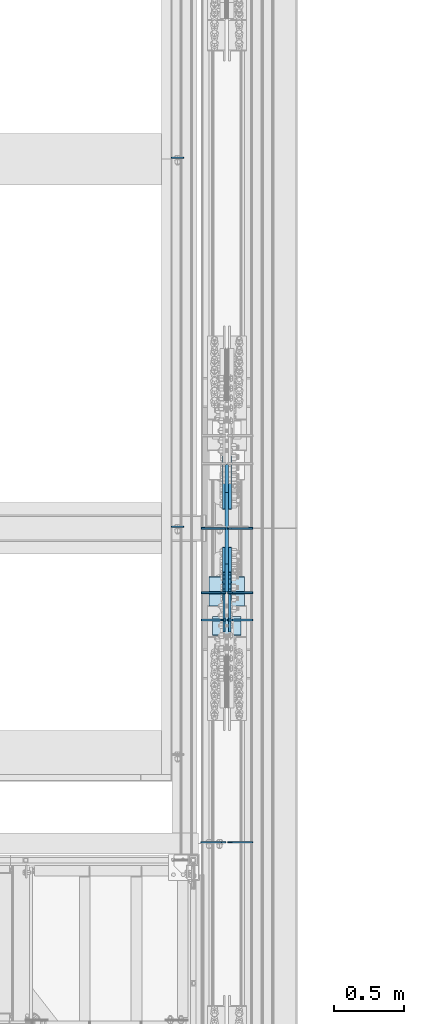
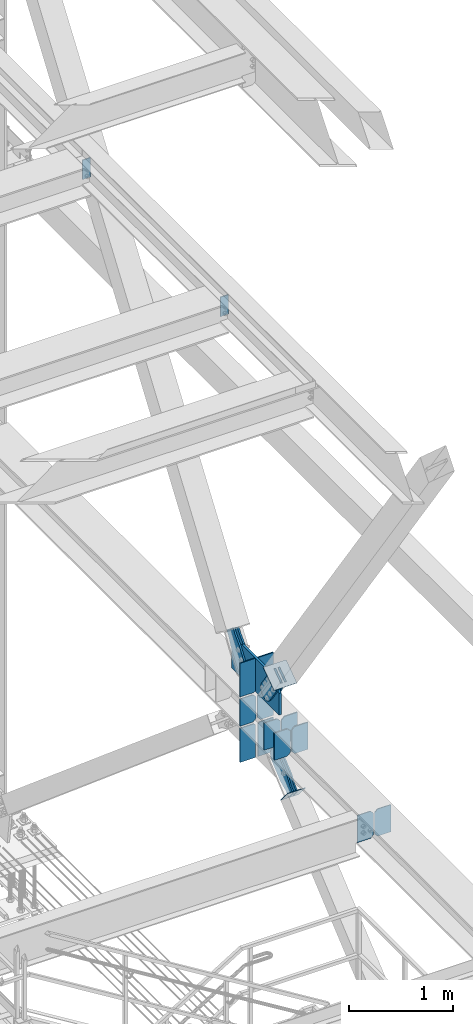
# One storey, part 3572 of 3843: 23 plates, 10 elements without a shape of their own.
"""IFC2X3 building model written with IfcOpenShell, lengths in millimetres."""

from ifc_helpers import new_model, si_unit, frame, origin_with_axes, place, context, subcontext, project, spatial, faceted_brep, material, type_object, element, aggregate, save


model = new_model("IFC2X3")

# Units and contexts
model_context = context("Model", 3, precision=1e-05, world=origin_with_axes())
body_context = subcontext(model_context, "Body", "Model", "MODEL_VIEW")
ifc_project = project(units=[si_unit("LENGTHUNIT", "METRE", prefix="MILLI"), si_unit("AREAUNIT", "SQUARE_METRE"), si_unit("VOLUMEUNIT", "CUBIC_METRE"), si_unit("MASSUNIT", "GRAM", prefix="KILO"), si_unit("TIMEUNIT", "SECOND"), si_unit("PLANEANGLEUNIT", "RADIAN"), si_unit("SOLIDANGLEUNIT", "STERADIAN"), si_unit("THERMODYNAMICTEMPERATUREUNIT", "DEGREE_CELSIUS"), si_unit("LUMINOUSINTENSITYUNIT", "LUMEN")], contexts=[model_context])

# Site, building, storey
site_placement = place(None, origin_with_axes())
site = spatial("IfcSite", under=ifc_project, at=site_placement, CompositionType="ELEMENT")
building_placement = place(site_placement, origin_with_axes())
building = spatial("IfcBuilding", under=site, at=building_placement, Name="Undefined", CompositionType="ELEMENT")
storey_placement = place(building_placement, origin_with_axes())
storey = spatial("IfcBuildingStorey", under=building, at=storey_placement, Name="Undefined", CompositionType="ELEMENT", Elevation=0.0)

# Assembly, plates
assembly_1_placement = place(storey_placement, origin_with_axes())
assembly_1 = element("IfcElementAssembly", 1, at=assembly_1_placement, inside=storey, Name="BEAM", AssemblyPlace="NOTDEFINED", PredefinedType="RIGID_FRAME")
ifc_material_1 = material(Name="STEEL/A572-50")
plate_type_1 = type_object("IfcPlateType", PredefinedType="NOTDEFINED")
plate_1_placement = place(assembly_1_placement, frame((85338.44375, 20317.61875, 39573.2), z_axis=(-1.0, 0.0, 0.0), x_axis=(0.0, 0.0, -1.0)))
plate_1 = element("IfcPlate", 2, at=plate_1_placement, type_object=plate_type_1, material=ifc_material_1, Name="PLATE", context=body_context, shape_type="Brep", body=[
    faceted_brep([(0.0, -4.76249999999709, 0.0), (0.0, -4.76249999999709, 88.9000015258789), (0.0, 4.76249999999709, 88.9000015258789), (0.0, 4.76249999999709, 0.0), (228.600006102781, -4.7625000004191, 88.9000015257589), (228.600006102781, 4.76249999954598, 88.9000015257443), (228.600006103079, -4.7625000004482, 7.27595761418343e-12), (228.600006103079, 4.76249999954598, -7.27595761418343e-12)], [[[0, 1, 2, 3]], [[1, 4, 5, 2]], [[4, 6, 7, 5]], [[6, 0, 3, 7]], [[5, 7, 3, 2]], [[6, 4, 1, 0]]]),
])
plate_2_placement = place(assembly_1_placement, frame((85338.44375, 22971.91875, 39573.2), z_axis=(-1.0, 0.0, 0.0), x_axis=(0.0, 0.0, -1.0)))
plate_2 = element("IfcPlate", 3, at=plate_2_placement, type_object=plate_type_1, material=ifc_material_1, Name="PLATE", context=body_context, shape_type="Brep", body=[
    faceted_brep([(0.0, -4.76249999999709, 0.0), (0.0, -4.76249999999709, 88.9000015258789), (0.0, 4.76249999999709, 88.9000015258789), (0.0, 4.76249999999709, 0.0), (228.600006102781, -4.7625000004191, 88.9000015257589), (228.600006102781, 4.76249999954598, 88.9000015257443), (228.600006103079, -4.7625000004482, 7.27595761418343e-12), (228.600006103079, 4.76249999954598, -7.27595761418343e-12)], [[[0, 1, 2, 3]], [[1, 4, 5, 2]], [[4, 6, 7, 5]], [[6, 0, 3, 7]], [[5, 7, 3, 2]], [[6, 4, 1, 0]]]),
])
aggregate(assembly_1, [plate_1, plate_2])

assembly_2_placement = place(storey_placement, origin_with_axes())
assembly_2 = element("IfcElementAssembly", 4, at=assembly_2_placement, inside=storey, Name="BEAM", AssemblyPlace="NOTDEFINED", PredefinedType="RIGID_FRAME")
plate_type_2 = type_object("IfcPlateType", PredefinedType="NOTDEFINED")
plate_3_placement = place(assembly_2_placement, frame((85641.65625, 19647.4953120779, 34467.8), z_axis=(-1.0, 0.0, 0.0), x_axis=(0.0, 0.0, 1.0)))
plate_3 = element("IfcPlate", 5, at=plate_3_placement, type_object=plate_type_2, material=ifc_material_1, Name="CB_BEAM", context=body_context, shape_type="Brep", body=[
    faceted_brep([(0.0, -6.34999999999854, 33.3375015258789), (0.0, -6.34999999999854, 178.59375), (0.0, 6.34999999999854, 178.59375), (0.0, 6.34999999999854, 33.3375015258789), (317.499999999985, -6.34999999999854, 178.59375), (317.499999999985, 6.34999999999854, 178.59375), (317.499999999985, -6.34999999999854, 33.3375015258789), (317.499999999985, 6.34999999999854, 33.3375015258789), (284.162498474107, -6.34999999999854, 0.0), (284.162498474107, 6.34999999999854, 0.0), (33.3375015258789, -6.34999999999854, 0.0), (33.3375015258789, 6.34999999999854, 0.0)], [[[0, 1, 2, 3]], [[1, 4, 5, 2]], [[4, 6, 7, 5]], [[6, 8, 9, 7]], [[8, 10, 11, 9]], [[10, 0, 3, 11]], [[5, 7, 9, 11, 3, 2]], [[10, 8, 6, 4, 1, 0]]]),
])
plate_4_placement = place(assembly_2_placement, frame((85641.65625, 19843.5515620779, 34467.8), z_axis=(-1.0, 0.0, 0.0), x_axis=(0.0, 0.0, 1.0)))
plate_4 = element("IfcPlate", 6, at=plate_4_placement, type_object=plate_type_2, material=ifc_material_1, Name="CB_BEAM", context=body_context, shape_type="Brep", body=[
    faceted_brep([(0.0, -6.34999999999854, 33.3375015258789), (0.0, -6.34999999999854, 178.59375), (0.0, 6.34999999999854, 178.59375), (0.0, 6.34999999999854, 33.3375015258789), (317.499999999985, -6.34999999999854, 178.59375), (317.499999999985, 6.34999999999854, 178.59375), (317.499999999985, -6.34999999999854, 33.3375015258789), (317.499999999985, 6.34999999999854, 33.3375015258789), (284.162498474107, -6.34999999999854, 0.0), (284.162498474107, 6.34999999999854, 0.0), (33.3375015258789, -6.34999999999854, 0.0), (33.3375015258789, 6.34999999999854, 0.0)], [[[0, 1, 2, 3]], [[1, 4, 5, 2]], [[4, 6, 7, 5]], [[6, 8, 9, 7]], [[8, 10, 11, 9]], [[10, 0, 3, 11]], [[5, 7, 9, 11, 3, 2]], [[10, 8, 6, 4, 1, 0]]]),
])
plate_5_placement = place(assembly_2_placement, frame((85655.94375, 19647.4953120779, 34467.8), z_axis=(1.0, 0.0, 0.0), x_axis=(0.0, 0.0, 1.0)))
plate_5 = element("IfcPlate", 7, at=plate_5_placement, type_object=plate_type_2, material=ifc_material_1, Name="CB_BEAM", context=body_context, shape_type="Brep", body=[
    faceted_brep([(0.0, -6.34999999999854, 33.3375015258789), (0.0, -6.34999999999854, 178.59375), (0.0, 6.34999999999854, 178.59375), (0.0, 6.34999999999854, 33.3375015258789), (317.499999999985, -6.34999999999854, 178.59375), (317.499999999985, 6.34999999999854, 178.59375), (317.499999999985, -6.34999999999854, 33.3375015258789), (317.499999999985, 6.34999999999854, 33.3375015258789), (284.162498474107, -6.34999999999854, 0.0), (284.162498474107, 6.34999999999854, 0.0), (33.3375015258789, -6.34999999999854, 0.0), (33.3375015258789, 6.34999999999854, 0.0)], [[[0, 1, 2, 3]], [[1, 4, 5, 2]], [[4, 6, 7, 5]], [[6, 8, 9, 7]], [[8, 10, 11, 9]], [[10, 0, 3, 11]], [[5, 7, 9, 11, 3, 2]], [[10, 8, 6, 4, 1, 0]]]),
])
plate_6_placement = place(assembly_2_placement, frame((85655.94375, 19843.5515620779, 34467.8), z_axis=(1.0, 0.0, 0.0), x_axis=(0.0, 0.0, 1.0)))
plate_6 = element("IfcPlate", 8, at=plate_6_placement, type_object=plate_type_2, material=ifc_material_1, Name="CB_BEAM", context=body_context, shape_type="Brep", body=[
    faceted_brep([(0.0, -6.34999999999854, 33.3375015258789), (0.0, -6.34999999999854, 178.59375), (0.0, 6.34999999999854, 178.59375), (0.0, 6.34999999999854, 33.3375015258789), (317.499999999985, -6.34999999999854, 178.59375), (317.499999999985, 6.34999999999854, 178.59375), (317.499999999985, -6.34999999999854, 33.3375015258789), (317.499999999985, 6.34999999999854, 33.3375015258789), (284.162498474107, -6.34999999999854, 0.0), (284.162498474107, 6.34999999999854, 0.0), (33.3375015258789, -6.34999999999854, 0.0), (33.3375015258789, 6.34999999999854, 0.0)], [[[0, 1, 2, 3]], [[1, 4, 5, 2]], [[4, 6, 7, 5]], [[6, 8, 9, 7]], [[8, 10, 11, 9]], [[10, 0, 3, 11]], [[5, 7, 9, 11, 3, 2]], [[10, 8, 6, 4, 1, 0]]]),
])
plate_7_placement = place(assembly_2_placement, frame((85641.65625, 20307.3000000779, 34467.8), z_axis=(-1.0, 0.0, 0.0), x_axis=(0.0, 0.0, 1.0)))
plate_7 = element("IfcPlate", 9, at=plate_7_placement, type_object=plate_type_2, material=ifc_material_1, Name="CB_BEAM", context=body_context, shape_type="Brep", body=[
    faceted_brep([(0.0, -6.34999999999854, 33.3375015258789), (0.0, -6.34999999999854, 178.59375), (0.0, 6.34999999999854, 178.59375), (0.0, 6.34999999999854, 33.3375015258789), (317.499999999985, -6.34999999999854, 178.59375), (317.499999999985, 6.34999999999854, 178.59375), (317.499999999985, -6.34999999999854, 33.3375015258789), (317.499999999985, 6.34999999999854, 33.3375015258789), (284.162498474107, -6.34999999999854, 0.0), (284.162498474107, 6.34999999999854, 0.0), (33.3375015258789, -6.34999999999854, 0.0), (33.3375015258789, 6.34999999999854, 0.0)], [[[0, 1, 2, 3]], [[1, 4, 5, 2]], [[4, 6, 7, 5]], [[6, 8, 9, 7]], [[8, 10, 11, 9]], [[10, 0, 3, 11]], [[5, 7, 9, 11, 3, 2]], [[10, 8, 6, 4, 1, 0]]]),
])
plate_8_placement = place(assembly_2_placement, frame((85655.94375, 20307.3000000779, 34467.8), z_axis=(1.0, 0.0, 0.0), x_axis=(0.0, 0.0, 1.0)))
plate_8 = element("IfcPlate", 10, at=plate_8_placement, type_object=plate_type_2, material=ifc_material_1, Name="CB_BEAM", context=body_context, shape_type="Brep", body=[
    faceted_brep([(0.0, -6.34999999999854, 33.3375015258789), (0.0, -6.34999999999854, 178.59375), (0.0, 6.34999999999854, 178.59375), (0.0, 6.34999999999854, 33.3375015258789), (317.499999999985, -6.34999999999854, 178.59375), (317.499999999985, 6.34999999999854, 178.59375), (317.499999999985, -6.34999999999854, 33.3375015258789), (317.499999999985, 6.34999999999854, 33.3375015258789), (284.162498474107, -6.34999999999854, 0.0), (284.162498474107, 6.34999999999854, 0.0), (33.3375015258789, -6.34999999999854, 0.0), (33.3375015258789, 6.34999999999854, 0.0)], [[[0, 1, 2, 3]], [[1, 4, 5, 2]], [[4, 6, 7, 5]], [[6, 8, 9, 7]], [[8, 10, 11, 9]], [[10, 0, 3, 11]], [[5, 7, 9, 11, 3, 2]], [[10, 8, 6, 4, 1, 0]]]),
])
plate_type_3 = type_object("IfcPlateType", PredefinedType="NOTDEFINED")
plate_9_placement = place(assembly_2_placement, frame((85636.1, 20307.3000000779, 34042.945312), z_axis=(-1.0, 0.0, 0.0), x_axis=(0.0, 0.0, 1.0)))
plate_9 = element("IfcPlate", 11, at=plate_9_placement, type_object=plate_type_3, material=ifc_material_1, Name="CB", context=body_context, shape_type="Brep", body=[
    faceted_brep([(0.0, -6.3499999046162, 0.0), (0.0, -6.34999999999854, 173.037500000006), (0.0, 6.34999999999854, 173.037500000006), (7.27595761418343e-12, 6.3499999046162, 0.0), (399.501140829176, -6.34999999999854, 173.037500000006), (399.501140829176, 6.34999999999854, 173.037500000006), (399.501140829176, -6.34999999999854, 19.0499992370605), (399.501140829176, 6.34999999999854, 19.0499992370605), (380.451141592115, -6.34999999999854, 0.0), (380.451141592115, 6.34999999999854, 0.0)], [[[0, 1, 2, 3]], [[1, 4, 5, 2]], [[4, 6, 7, 5]], [[6, 8, 9, 7]], [[8, 0, 3, 9]], [[5, 7, 9, 3, 2]], [[8, 6, 4, 1, 0]]]),
])
plate_10_placement = place(assembly_2_placement, frame((85661.5, 20307.3000000779, 34042.945312), z_axis=(1.0, 0.0, 0.0), x_axis=(0.0, 0.0, 1.0)))
plate_10 = element("IfcPlate", 12, at=plate_10_placement, type_object=plate_type_3, material=ifc_material_1, Name="CB", context=body_context, shape_type="Brep", body=[
    faceted_brep([(0.0, -6.3499999046162, 0.0), (0.0, -6.34999999999854, 173.037500000006), (0.0, 6.34999999999854, 173.037500000006), (7.27595761418343e-12, 6.3499999046162, 0.0), (399.501140829176, -6.34999999999854, 173.037500000006), (399.501140829176, 6.34999999999854, 173.037500000006), (399.501140829176, -6.34999999999854, 19.0499992370605), (399.501140829176, 6.34999999999854, 19.0499992370605), (380.451141592115, -6.34999999999854, 0.0), (380.451141592115, 6.34999999999854, 0.0)], [[[0, 1, 2, 3]], [[1, 4, 5, 2]], [[4, 6, 7, 5]], [[6, 8, 9, 7]], [[8, 0, 3, 9]], [[5, 7, 9, 3, 2]], [[8, 6, 4, 1, 0]]]),
])
plate_11_placement = place(assembly_2_placement, frame((85636.1, 20307.3000000779, 34810.7), z_axis=(-1.0, 0.0, 0.0), x_axis=(0.0, 0.0, 1.0)))
plate_11 = element("IfcPlate", 13, at=plate_11_placement, type_object=plate_type_3, material=ifc_material_1, Name="CB", context=body_context, shape_type="Brep", body=[
    faceted_brep([(0.0, -6.34999999999854, 19.0499992370605), (0.0, -6.34999999999854, 173.037500000006), (0.0, 6.34999999999854, 173.037500000006), (0.0, 6.34999999999854, 19.0499992370605), (395.551005629044, -6.34999999999854, 173.037500000006), (395.551005629044, 6.34999999999854, 173.037500000006), (395.551005629044, -6.34999999999854, 0.0), (395.551005629044, 6.34999999999854, 0.0), (19.0499992370605, -6.34999999999854, 0.0), (19.0499992370605, 6.34999999999854, 0.0)], [[[0, 1, 2, 3]], [[1, 4, 5, 2]], [[4, 6, 7, 5]], [[6, 8, 9, 7]], [[8, 0, 3, 9]], [[5, 7, 9, 3, 2]], [[8, 6, 4, 1, 0]]]),
])
plate_12_placement = place(assembly_2_placement, frame((85661.5, 20307.3000000779, 34810.7), z_axis=(1.0, 0.0, 0.0), x_axis=(0.0, 0.0, 1.0)))
plate_12 = element("IfcPlate", 14, at=plate_12_placement, type_object=plate_type_3, material=ifc_material_1, Name="CB", context=body_context, shape_type="Brep", body=[
    faceted_brep([(0.0, -6.34999999999854, 19.0499992370605), (0.0, -6.34999999999854, 173.037500000006), (0.0, 6.34999999999854, 173.037500000006), (0.0, 6.34999999999854, 19.0499992370605), (395.551005629044, -6.34999999999854, 173.037500000006), (395.551005629044, 6.34999999999854, 173.037500000006), (395.551005629044, -6.34999999999854, 0.0), (395.551005629044, 6.34999999999854, 0.0), (19.0499992370605, -6.34999999999854, 0.0), (19.0499992370605, 6.34999999999854, 0.0)], [[[0, 1, 2, 3]], [[1, 4, 5, 2]], [[4, 6, 7, 5]], [[6, 8, 9, 7]], [[8, 0, 3, 9]], [[5, 7, 9, 3, 2]], [[8, 6, 4, 1, 0]]]),
])

# Assembly, plate
assembly_3_placement = place(storey_placement, origin_with_axes())
assembly_3 = element("IfcElementAssembly", 15, at=assembly_3_placement, inside=storey, Name="Plate", AssemblyPlace="NOTDEFINED", PredefinedType="RIGID_FRAME")
ifc_material_2 = material(Name="STEEL/A36")
plate_type_4 = type_object("IfcPlateType", PredefinedType="NOTDEFINED")
plate_13_placement = place(assembly_3_placement, frame((85750.4, 19668.5188615773, 33954.9730855109), z_axis=(0.0, -0.644671805294096, 0.764459458348742), x_axis=(-1.0, 0.0, 0.0)))
plate_13 = element("IfcPlate", 16, at=plate_13_placement, type_object=plate_type_4, material=ifc_material_2, Name="Plate", context=body_context, shape_type="Brep", body=[
    faceted_brep([(0.0, -3.17499999999927, 0.0), (0.0, -3.17500000043947, 203.200000001736), (0.0, 3.1749999995518, 203.200000001743), (0.0, 3.17499999999927, 0.0), (203.200000000012, -3.17500000043947, 203.200000001736), (203.200000000012, 3.1749999995518, 203.200000001743), (203.199996948242, -3.17499999999927, 0.0), (203.199996948242, 3.17499999999927, 0.0)], [[[0, 1, 2, 3]], [[1, 4, 5, 2]], [[4, 6, 7, 5]], [[6, 0, 3, 7]], [[5, 7, 3, 2]], [[6, 4, 1, 0]]]),
])
aggregate(assembly_3, [plate_13])

assembly_4_placement = place(storey_placement, origin_with_axes())
assembly_4 = element("IfcElementAssembly", 17, at=assembly_4_placement, inside=storey, AssemblyPlace="NOTDEFINED", PredefinedType="RIGID_FRAME")
plate_type_5 = type_object("IfcPlateType", PredefinedType="NOTDEFINED")
plate_14_placement = place(assembly_4_placement, frame((85626.575, 19916.4216353851, 35321.9193432477), z_axis=(0.0, -0.818772763967613, -0.574117723977265), x_axis=(0.0, 0.574117723977282, -0.818772763967601)))
plate_14 = element("IfcPlate", 18, at=plate_14_placement, type_object=plate_type_5, material=ifc_material_2, context=body_context, shape_type="Brep", body=[
    faceted_brep([(0.0, -9.52500000000146, 0.0), (1.71894498635083e-09, -9.52499999999418, 158.39421297863), (1.71894498635083e-09, 9.52499999999418, 158.39421297863), (0.0, 9.52500000000146, 0.0), (69.8500000010408, -9.52499999999418, 158.394212979103), (69.8500000010408, 9.52499999999418, 158.394212979103), (171.450000002631, -9.52499999999418, 176.034606488582), (171.450000002631, 9.52499999999418, 176.034606488582), (390.129297671807, -9.52499999999418, 176.034606487716), (390.129297671807, 9.52499999999418, 176.034606487716), (427.187405137312, -9.52499999999418, 168.663290600991), (427.187405137312, 9.52499999999418, 168.663290600991), (458.60375167372, -9.52499999999418, 147.671558963724), (458.60375167372, 9.52499999999418, 147.671558963724), (479.59548331075, -9.52499999999418, 116.255212427161), (479.59548331075, 9.52499999999418, 116.255212427161), (486.966799197198, -9.52499999999418, 79.1971080138683), (486.966799197198, 9.52499999999418, 79.1971080138683), (479.595483310488, -9.52499999999418, 42.1390005483336), (479.595483310488, 9.52499999999418, 42.1390005483336), (458.603751673207, -9.52499999999418, 10.7226540119082), (458.603751673207, 9.52499999999418, 10.7226540119082), (427.18740513661, -9.52499999999418, -10.2690776251402), (427.18740513661, 9.52499999999418, -10.2690776251402), (390.129299195723, -9.52499999999418, -17.6403935115741), (390.129299195723, 9.52499999999418, -17.6403935115741), (171.450000001962, -9.52499999999418, -17.6403935107155), (171.450000001962, 9.52499999999418, -17.6403935107155), (69.8499999979995, -9.52499999999418, -4.00177668780088e-10), (69.8499999979995, 9.52499999999418, -4.00177668780088e-10)], [[[0, 1, 2, 3]], [[1, 4, 5, 2]], [[4, 6, 7, 5]], [[6, 8, 9, 7]], [[8, 10, 11, 9]], [[10, 12, 13, 11]], [[12, 14, 15, 13]], [[14, 16, 17, 15]], [[16, 18, 19, 17]], [[18, 20, 21, 19]], [[20, 22, 23, 21]], [[22, 24, 25, 23]], [[24, 26, 27, 25]], [[26, 28, 29, 27]], [[28, 0, 3, 29]], [[5, 7, 9, 11, 13, 15, 17, 19, 21, 23, 25, 27, 29, 3, 2]], [[28, 26, 24, 22, 20, 18, 16, 14, 12, 10, 8, 6, 4, 1, 0]]]),
])
aggregate(assembly_4, [plate_14])

assembly_5_placement = place(storey_placement, origin_with_axes())
assembly_5 = element("IfcElementAssembly", 19, at=assembly_5_placement, inside=storey, AssemblyPlace="NOTDEFINED", PredefinedType="RIGID_FRAME")
plate_15_placement = place(assembly_5_placement, frame((85671.025, 19916.4216353851, 35321.9193432477), z_axis=(0.0, -0.818772763967613, -0.574117723977265), x_axis=(0.0, 0.574117723977282, -0.818772763967601)))
plate_15 = element("IfcPlate", 20, at=plate_15_placement, type_object=plate_type_5, material=ifc_material_2, context=body_context, shape_type="Brep", body=[
    faceted_brep([(0.0, -9.52500000000146, 0.0), (1.71894498635083e-09, -9.52499999999418, 158.39421297863), (1.71894498635083e-09, 9.52499999999418, 158.39421297863), (0.0, 9.52500000000146, 0.0), (69.8500000010408, -9.52499999999418, 158.394212979103), (69.8500000010408, 9.52499999999418, 158.394212979103), (171.450000002631, -9.52499999999418, 176.034606488582), (171.450000002631, 9.52499999999418, 176.034606488582), (390.129297671807, -9.52499999999418, 176.034606487716), (390.129297671807, 9.52499999999418, 176.034606487716), (427.187405137312, -9.52499999999418, 168.663290600991), (427.187405137312, 9.52499999999418, 168.663290600991), (458.60375167372, -9.52499999999418, 147.671558963724), (458.60375167372, 9.52499999999418, 147.671558963724), (479.59548331075, -9.52499999999418, 116.255212427161), (479.59548331075, 9.52499999999418, 116.255212427161), (486.966799197198, -9.52499999999418, 79.1971080138683), (486.966799197198, 9.52499999999418, 79.1971080138683), (479.595483310488, -9.52499999999418, 42.1390005483336), (479.595483310488, 9.52499999999418, 42.1390005483336), (458.603751673207, -9.52499999999418, 10.7226540119082), (458.603751673207, 9.52499999999418, 10.7226540119082), (427.18740513661, -9.52499999999418, -10.2690776251402), (427.18740513661, 9.52499999999418, -10.2690776251402), (390.129299195723, -9.52499999999418, -17.6403935115741), (390.129299195723, 9.52499999999418, -17.6403935115741), (171.450000001962, -9.52499999999418, -17.6403935107155), (171.450000001962, 9.52499999999418, -17.6403935107155), (69.8499999979995, -9.52499999999418, -4.00177668780088e-10), (69.8499999979995, 9.52499999999418, -4.00177668780088e-10)], [[[0, 1, 2, 3]], [[1, 4, 5, 2]], [[4, 6, 7, 5]], [[6, 8, 9, 7]], [[8, 10, 11, 9]], [[10, 12, 13, 11]], [[12, 14, 15, 13]], [[14, 16, 17, 15]], [[16, 18, 19, 17]], [[18, 20, 21, 19]], [[20, 22, 23, 21]], [[22, 24, 25, 23]], [[24, 26, 27, 25]], [[26, 28, 29, 27]], [[28, 0, 3, 29]], [[5, 7, 9, 11, 13, 15, 17, 19, 21, 23, 25, 27, 29, 3, 2]], [[28, 26, 24, 22, 20, 18, 16, 14, 12, 10, 8, 6, 4, 1, 0]]]),
])
aggregate(assembly_5, [plate_15])

assembly_6_placement = place(storey_placement, origin_with_axes())
assembly_6 = element("IfcElementAssembly", 21, at=assembly_6_placement, inside=storey, AssemblyPlace="NOTDEFINED", PredefinedType="RIGID_FRAME")
plate_16_placement = place(assembly_6_placement, frame((85626.575, 20787.7490710285, 35173.7904243102), z_axis=(0.0, -0.818771907061984, 0.574118946043485), x_axis=(0.0, 0.57411894604347, 0.818771907061994)))
plate_16 = element("IfcPlate", 22, at=plate_16_placement, type_object=plate_type_5, material=ifc_material_2, context=body_context, shape_type="Brep", body=[
    faceted_brep([(0.0, -9.52500000000146, 0.0), (-101.599999999169, -9.52499999999418, -17.6403935107228), (-101.599999999169, 9.52499999999418, -17.6403935107228), (0.0, 9.52500000000146, 0.0), (-320.279297659972, -9.52499999999418, -17.640393512258), (-320.279297659972, 9.52499999999418, -17.640393512258), (-357.3374051259, -9.52499999999418, -10.2690776257878), (-357.3374051259, 9.52499999999418, -10.2690776257878), (-388.753751662653, -9.52499999999418, 10.7226540115298), (-388.753751662653, 9.52499999999418, 10.7226540115298), (-409.745483299826, -9.52499999999418, 42.1390005483918), (-409.745483299826, 9.52499999999418, 42.1390005483918), (-417.116799186137, -9.52499999999418, 79.1971049608474), (-417.116799186137, 9.52499999999418, 79.1971049608474), (-409.745483299252, -9.52499999999418, 116.255212426157), (-409.745483299252, 9.52499999999418, 116.255212426157), (-388.75375166202, -9.52499999999418, 147.671558962465), (-388.75375166202, 9.52499999999418, 147.671558962465), (-357.33740512564, -9.52499999999418, 168.663290599579), (-357.33740512564, 9.52499999999418, 168.663290599579), (-320.279299186061, -9.52499999999418, 176.034606486319), (-320.279299186061, 9.52499999999418, 176.034606486319), (-101.599999997048, -9.52499999999418, 176.034606487883), (-101.599999997048, 9.52499999999418, 176.034606487883), (1.71894498635083e-09, -9.52499999999418, 158.39421297863), (1.71894498635083e-09, 9.52499999999418, 158.39421297863), (69.8500000010408, -9.52499999999418, 158.394212979103), (69.8500000010408, 9.52499999999418, 158.394212979103), (69.8499999979995, -9.52499999999418, -4.00177668780088e-10), (69.8499999979995, 9.52499999999418, -4.00177668780088e-10)], [[[0, 1, 2, 3]], [[1, 4, 5, 2]], [[4, 6, 7, 5]], [[6, 8, 9, 7]], [[8, 10, 11, 9]], [[10, 12, 13, 11]], [[12, 14, 15, 13]], [[14, 16, 17, 15]], [[16, 18, 19, 17]], [[18, 20, 21, 19]], [[20, 22, 23, 21]], [[22, 24, 25, 23]], [[24, 26, 27, 25]], [[26, 28, 29, 27]], [[28, 0, 3, 29]], [[5, 7, 9, 11, 13, 15, 17, 19, 21, 23, 25, 27, 29, 3, 2]], [[28, 26, 24, 22, 20, 18, 16, 14, 12, 10, 8, 6, 4, 1, 0]]]),
])
aggregate(assembly_6, [plate_16])

assembly_7_placement = place(storey_placement, origin_with_axes())
assembly_7 = element("IfcElementAssembly", 23, at=assembly_7_placement, inside=storey, AssemblyPlace="NOTDEFINED", PredefinedType="RIGID_FRAME")
plate_17_placement = place(assembly_7_placement, frame((85671.025, 20787.7490710285, 35173.7904243102), z_axis=(0.0, -0.818771907061984, 0.574118946043485), x_axis=(0.0, 0.57411894604347, 0.818771907061994)))
plate_17 = element("IfcPlate", 24, at=plate_17_placement, type_object=plate_type_5, material=ifc_material_2, context=body_context, shape_type="Brep", body=[
    faceted_brep([(0.0, -9.52500000000146, 0.0), (-101.599999999169, -9.52499999999418, -17.6403935107228), (-101.599999999169, 9.52499999999418, -17.6403935107228), (0.0, 9.52500000000146, 0.0), (-320.279297659972, -9.52499999999418, -17.640393512258), (-320.279297659972, 9.52499999999418, -17.640393512258), (-357.3374051259, -9.52499999999418, -10.2690776257878), (-357.3374051259, 9.52499999999418, -10.2690776257878), (-388.753751662653, -9.52499999999418, 10.7226540115298), (-388.753751662653, 9.52499999999418, 10.7226540115298), (-409.745483299826, -9.52499999999418, 42.1390005483918), (-409.745483299826, 9.52499999999418, 42.1390005483918), (-417.116799186137, -9.52499999999418, 79.1971049608474), (-417.116799186137, 9.52499999999418, 79.1971049608474), (-409.745483299252, -9.52499999999418, 116.255212426157), (-409.745483299252, 9.52499999999418, 116.255212426157), (-388.75375166202, -9.52499999999418, 147.671558962465), (-388.75375166202, 9.52499999999418, 147.671558962465), (-357.33740512564, -9.52499999999418, 168.663290599579), (-357.33740512564, 9.52499999999418, 168.663290599579), (-320.279299186061, -9.52499999999418, 176.034606486319), (-320.279299186061, 9.52499999999418, 176.034606486319), (-101.599999997048, -9.52499999999418, 176.034606487883), (-101.599999997048, 9.52499999999418, 176.034606487883), (1.71894498635083e-09, -9.52499999999418, 158.39421297863), (1.71894498635083e-09, 9.52499999999418, 158.39421297863), (69.8500000010408, -9.52499999999418, 158.394212979103), (69.8500000010408, 9.52499999999418, 158.394212979103), (69.8499999979995, -9.52499999999418, -4.00177668780088e-10), (69.8499999979995, 9.52499999999418, -4.00177668780088e-10)], [[[0, 1, 2, 3]], [[1, 4, 5, 2]], [[4, 6, 7, 5]], [[6, 8, 9, 7]], [[8, 10, 11, 9]], [[10, 12, 13, 11]], [[12, 14, 15, 13]], [[14, 16, 17, 15]], [[16, 18, 19, 17]], [[18, 20, 21, 19]], [[20, 22, 23, 21]], [[22, 24, 25, 23]], [[24, 26, 27, 25]], [[26, 28, 29, 27]], [[28, 0, 3, 29]], [[5, 7, 9, 11, 13, 15, 17, 19, 21, 23, 25, 27, 29, 3, 2]], [[28, 26, 24, 22, 20, 18, 16, 14, 12, 10, 8, 6, 4, 1, 0]]]),
])
aggregate(assembly_7, [plate_17])

assembly_8_placement = place(storey_placement, origin_with_axes())
assembly_8 = element("IfcElementAssembly", 25, at=assembly_8_placement, inside=storey, Name="Plate", AssemblyPlace="NOTDEFINED", PredefinedType="RIGID_FRAME")
plate_type_6 = type_object("IfcPlateType", PredefinedType="NOTDEFINED")
plate_18_placement = place(assembly_8_placement, frame((85521.8, 19749.4158839505, 35200.938325967), z_axis=(0.0, 0.818772763967602, 0.574117723977281), x_axis=(1.0, 0.0, 0.0)))
plate_18 = element("IfcPlate", 26, at=plate_18_placement, type_object=plate_type_6, material=ifc_material_2, Name="Plate", context=body_context, shape_type="Brep", body=[
    faceted_brep([(0.0, -3.17499999999927, 0.0), (0.0, -3.17499999965185, 254.000000005151), (0.0, 3.17500000035216, 254.000000005166), (0.0, 3.17499999999927, 0.0), (254.0, -3.17499999965185, 254.000000005151), (254.0, 3.17500000035216, 254.000000005166), (254.0, -3.17500000000291, 0.0), (254.0, 3.17499999999927, 1.45519152283669e-11)], [[[0, 1, 2, 3]], [[1, 4, 5, 2]], [[4, 6, 7, 5]], [[6, 0, 3, 7]], [[5, 7, 3, 2]], [[6, 4, 1, 0]]]),
])
aggregate(assembly_8, [plate_18])

assembly_9_placement = place(storey_placement, origin_with_axes())
assembly_9 = element("IfcElementAssembly", 27, at=assembly_9_placement, inside=storey, AssemblyPlace="NOTDEFINED", PredefinedType="RIGID_FRAME")
plate_type_7 = type_object("IfcPlateType", PredefinedType="NOTDEFINED")
plate_19_placement = place(assembly_9_placement, frame((85628.1625, 19641.6932293972, 33981.8582511154), z_axis=(0.0, -0.644671805294096, 0.764459458348742), x_axis=(0.0, 0.764459458348741, 0.644671805294097)))
plate_19 = element("IfcPlate", 28, at=plate_19_placement, type_object=plate_type_7, material=ifc_material_2, context=body_context, shape_type="Brep", body=[
    faceted_brep([(0.0, -7.9375, 0.0), (-4.01087163481861e-10, -7.9375, 127.507304269042), (-4.01087163481861e-10, 7.9375, 127.507304269042), (0.0, 7.9375, 0.0), (69.8499999986043, -7.9375, 127.507304268976), (69.8499999986043, 7.9375, 127.507304268976), (171.449999997779, -7.9375, 159.003652133302), (171.449999997779, 7.9375, 159.003652133302), (390.771138851001, -7.9375, 159.003652133724), (390.771138851001, 7.9375, 159.003652133724), (427.221735783516, -7.9375, 151.753177605606), (427.221735783516, 7.9375, 151.753177605606), (458.123059758641, -7.9375, 131.105573042281), (458.123059758641, 7.9375, 131.105573042281), (478.770664322428, -7.9375, 100.204249067465), (478.770664322428, 7.9375, 100.204249067465), (486.021138851092, -7.9375, 63.75365213646), (486.021138851092, 7.9375, 63.75365213646), (478.770664323177, -7.9375, 27.3030552033888), (478.770664323177, 7.9375, 27.3030552033888), (458.123059759649, -7.9375, -3.59826877222076), (458.123059759649, 7.9375, -3.59826877222076), (427.221735784352, -7.9375, -24.2458733362073), (427.221735784352, 7.9375, -24.2458733362073), (390.771138852427, -7.9375, -31.496347864675), (390.771138852427, 7.9375, -31.496347864675), (171.450000000242, -7.9375, -31.4963478651116), (171.450000000242, 7.9375, -31.4963478651116), (69.850000000486, -7.9375, 2.91038304567337e-11), (69.850000000486, 7.9375, 2.91038304567337e-11)], [[[0, 1, 2, 3]], [[1, 4, 5, 2]], [[4, 6, 7, 5]], [[6, 8, 9, 7]], [[8, 10, 11, 9]], [[10, 12, 13, 11]], [[12, 14, 15, 13]], [[14, 16, 17, 15]], [[16, 18, 19, 17]], [[18, 20, 21, 19]], [[20, 22, 23, 21]], [[22, 24, 25, 23]], [[24, 26, 27, 25]], [[26, 28, 29, 27]], [[28, 0, 3, 29]], [[5, 7, 9, 11, 13, 15, 17, 19, 21, 23, 25, 27, 29, 3, 2]], [[28, 26, 24, 22, 20, 18, 16, 14, 12, 10, 8, 6, 4, 1, 0]]]),
])
aggregate(assembly_9, [plate_19])

assembly_10_placement = place(storey_placement, origin_with_axes())
assembly_10 = element("IfcElementAssembly", 29, at=assembly_10_placement, inside=storey, AssemblyPlace="NOTDEFINED", PredefinedType="RIGID_FRAME")
plate_20_placement = place(assembly_10_placement, frame((85669.4375, 19641.6932293972, 33981.8582511154), z_axis=(0.0, -0.644671805294096, 0.764459458348742), x_axis=(0.0, 0.764459458348741, 0.644671805294097)))
plate_20 = element("IfcPlate", 30, at=plate_20_placement, type_object=plate_type_7, material=ifc_material_2, context=body_context, shape_type="Brep", body=[
    faceted_brep([(0.0, -7.9375, 0.0), (-4.01087163481861e-10, -7.9375, 127.507304269042), (-4.01087163481861e-10, 7.9375, 127.507304269042), (0.0, 7.9375, 0.0), (69.8499999986043, -7.9375, 127.507304268976), (69.8499999986043, 7.9375, 127.507304268976), (171.449999997779, -7.9375, 159.003652133302), (171.449999997779, 7.9375, 159.003652133302), (390.771138851001, -7.9375, 159.003652133724), (390.771138851001, 7.9375, 159.003652133724), (427.221735783516, -7.9375, 151.753177605606), (427.221735783516, 7.9375, 151.753177605606), (458.123059758641, -7.9375, 131.105573042281), (458.123059758641, 7.9375, 131.105573042281), (478.770664322428, -7.9375, 100.204249067465), (478.770664322428, 7.9375, 100.204249067465), (486.021138851092, -7.9375, 63.75365213646), (486.021138851092, 7.9375, 63.75365213646), (478.770664323177, -7.9375, 27.3030552033888), (478.770664323177, 7.9375, 27.3030552033888), (458.123059759649, -7.9375, -3.59826877222076), (458.123059759649, 7.9375, -3.59826877222076), (427.221735784352, -7.9375, -24.2458733362073), (427.221735784352, 7.9375, -24.2458733362073), (390.771138852427, -7.9375, -31.496347864675), (390.771138852427, 7.9375, -31.496347864675), (171.450000000242, -7.9375, -31.4963478651116), (171.450000000242, 7.9375, -31.4963478651116), (69.850000000486, -7.9375, 2.91038304567337e-11), (69.850000000486, 7.9375, 2.91038304567337e-11)], [[[0, 1, 2, 3]], [[1, 4, 5, 2]], [[4, 6, 7, 5]], [[6, 8, 9, 7]], [[8, 10, 11, 9]], [[10, 12, 13, 11]], [[12, 14, 15, 13]], [[14, 16, 17, 15]], [[16, 18, 19, 17]], [[18, 20, 21, 19]], [[20, 22, 23, 21]], [[22, 24, 25, 23]], [[24, 26, 27, 25]], [[26, 28, 29, 27]], [[28, 0, 3, 29]], [[5, 7, 9, 11, 13, 15, 17, 19, 21, 23, 25, 27, 29, 3, 2]], [[28, 26, 24, 22, 20, 18, 16, 14, 12, 10, 8, 6, 4, 1, 0]]]),
])
aggregate(assembly_10, [plate_20])

# Plate
plate_type_8 = type_object("IfcPlateType", PredefinedType="NOTDEFINED")
plate_21_placement = place(assembly_2_placement, frame((85655.94375, 18049.0817499161, 34467.8), z_axis=(0.0, 0.0, 1.0), x_axis=(1.0, 0.0, 0.0)))
plate_21 = element("IfcPlate", 31, at=plate_21_placement, type_object=plate_type_8, material=ifc_material_1, Name="PLATE", context=body_context, shape_type="Brep", body=[
    faceted_brep([(0.0, -4.76249999999709, 31.75), (0.0, -4.7624999997206, 285.749999997672), (0.0, 4.7625000002663, 285.749999997664), (0.0, 4.76249999999709, 31.75), (31.75, -4.76250000000073, 317.5), (31.75, 4.76250000000073, 317.5), (178.59375, -4.76250000000073, 317.5), (178.59375, 4.76250000000073, 317.5), (178.59375, -4.76250000000073, 0.0), (178.59375, 4.76250000000073, 0.0), (31.75, -4.76249999999709, 0.0), (31.75, 4.76249999999709, 0.0)], [[[0, 1, 2, 3]], [[1, 4, 5, 2]], [[4, 6, 7, 5]], [[6, 8, 9, 7]], [[8, 10, 11, 9]], [[10, 0, 3, 11]], [[5, 7, 9, 11, 3, 2]], [[10, 8, 6, 4, 1, 0]]]),
])

plate_22_placement = place(assembly_2_placement, frame((85641.65625, 18049.0817499161, 34467.8), z_axis=(0.0, 0.0, 1.0), x_axis=(-1.0, 0.0, 0.0)))
plate_22 = element("IfcPlate", 32, at=plate_22_placement, type_object=plate_type_8, material=ifc_material_1, Name="PLATE", context=body_context, shape_type="Brep", body=[
    faceted_brep([(0.0, -4.76249999999709, 31.75), (0.0, -4.76250000000073, 287.337493896484), (0.0, 4.76250000000073, 287.337493896484), (0.0, 4.76249999999709, 31.75), (31.75, -4.76250000000073, 319.087493896484), (31.75, 4.76250000000073, 319.087493896484), (179.387496948242, -4.76250000000073, 319.087493896484), (179.387496948242, 4.76250000000073, 319.087493896484), (179.387496948242, -4.76250000000073, 0.0), (179.387496948242, 4.76250000000073, 0.0), (31.75, -4.76249999999709, 0.0), (31.75, 4.76249999999709, 0.0)], [[[0, 1, 2, 3]], [[1, 4, 5, 2]], [[4, 6, 7, 5]], [[6, 8, 9, 7]], [[8, 10, 11, 9]], [[10, 0, 3, 11]], [[5, 7, 9, 11, 3, 2]], [[10, 8, 6, 4, 1, 0]]]),
])

plate_type_9 = type_object("IfcPlateType", PredefinedType="NOTDEFINED")
plate_23_placement = place(assembly_2_placement, frame((85648.8, 19849.9249496451, 34810.7), z_axis=(0.0, 1.0, 0.0), x_axis=(0.0, 0.0, 1.0)))
plate_23 = element("IfcPlate", 33, at=plate_23_placement, type_object=plate_type_9, material=ifc_material_1, Name="CB", context=body_context, shape_type="Brep", body=[
    faceted_brep([(0.0, -12.6999999999971, 0.0), (0.0, -12.6999999999971, 914.733901545111), (0.0, 12.6999999999971, 914.733901545111), (0.0, 12.6999999999971, 0.0), (255.192893189822, -12.6999999999971, 914.733901545111), (255.192893189822, 12.6999999999971, 914.733901545111), (395.551005629044, -12.6999999999971, 714.564093205809), (395.551005629044, 12.6999999999971, 714.564093205809), (395.551005629044, -12.6999999999971, 463.708195366555), (395.551005629044, 12.6999999999971, 463.708195366555), (395.551005629044, -12.6999999999971, 200.169471470981), (395.551005629044, 12.6999999999971, 200.169471470981), (255.193575059704, -12.6999999999971, 0.0), (255.193575059704, 12.6999999999971, 0.0)], [[[0, 1, 2, 3]], [[1, 4, 5, 2]], [[4, 6, 7, 5]], [[6, 8, 9, 7]], [[8, 10, 11, 9]], [[10, 12, 13, 11]], [[12, 0, 3, 13]], [[5, 7, 9, 11, 13, 3, 2]], [[12, 10, 8, 6, 4, 1, 0]]]),
])

aggregate(assembly_2, [plate_3, plate_4, plate_5, plate_6, plate_21, plate_22, plate_7, plate_8, plate_9, plate_10, plate_11, plate_12, plate_23])

save(model, "model.ifc")
